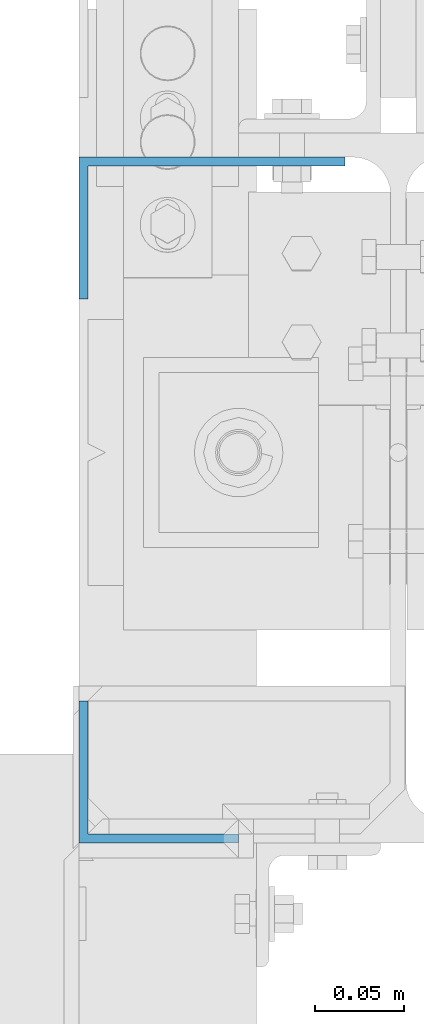
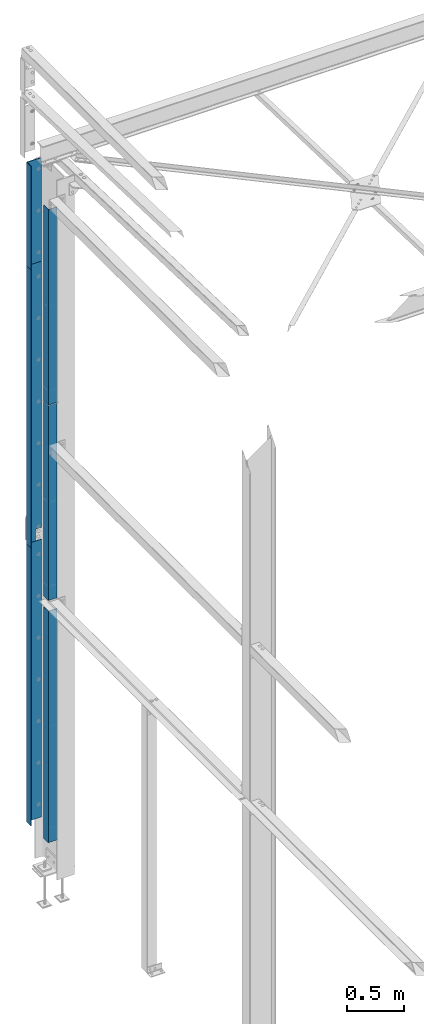
# One storey, part 345 of 496: 6 beams, 4 elements without a shape of their own.
"""IFC2X3 building model written with IfcOpenShell, lengths in millimetres."""

import ifcopenshell
import ifcopenshell.guid

model = None  # the IFC model being written
_history = None  # IfcOwnerHistory: only IFC2X3 demands one
_inside = {}  # id of a spatial element -> (the spatial element, [elements in it])
_under = {}  # id of a project, library or spatial element -> (it, [spatial elements below it])
_declared = {}  # id of a project -> (the project, [libraries it declares])
_typed = {}  # id of a type object -> (the type object, [elements of that type])
_made_of = {}  # id of a material, layer set ... -> (it, [elements and type objects made of it])


def new_model(schema):
    """Start an empty IFC model of exactly this schema.

    Asked for "IFC4X3", IfcOpenShell would pick the latest addendum, in which some entities
    have other attributes; the version numbers below select the first issue.
    IFC2X3 requires an IfcOwnerHistory on every rooted entity: one is made here for all.
    """
    global model, _history
    if schema == "IFC4X3":
        model = ifcopenshell.file(schema_version=(4, 3, 0, 0))
    else:
        model = ifcopenshell.file(schema=schema)
    _inside.clear()
    _under.clear()
    _declared.clear()
    _typed.clear()
    _made_of.clear()
    _history = None
    if model.schema == "IFC2X3":
        org = make("IfcOrganization", Name="unknown")
        user = make(
            "IfcPersonAndOrganization",
            ThePerson=make("IfcPerson", FamilyName="unknown"),
            TheOrganization=org,
        )
        app = make(
            "IfcApplication",
            ApplicationDeveloper=org,
            Version="unknown",
            ApplicationFullName="unknown",
            ApplicationIdentifier="unknown",
        )
        _history = make(
            "IfcOwnerHistory",
            OwningUser=user,
            OwningApplication=app,
            ChangeAction="ADDED",
            CreationDate=0,
        )
    return model


def make(cls, **values):
    """One entity of the class cls with the attributes given. An attribute that is None is left unset."""
    return model.create_entity(
        cls, **{name: value for name, value in values.items() if value is not None}
    )


def rooted(cls, **values):
    """An entity with a GlobalId (a new one), such as an element, a storey or a relation."""
    return make(cls, GlobalId=ifcopenshell.guid.new(), OwnerHistory=_history, **values)


def si_unit(unit_type, name, prefix=None):
    """IfcSIUnit, for example si_unit("LENGTHUNIT", "METRE", prefix="MILLI")."""
    return make("IfcSIUnit", UnitType=unit_type, Prefix=prefix, Name=name)


def assignment(units):
    """IfcUnitAssignment: the units of a project."""
    return None if units is None else make("IfcUnitAssignment", Units=units)


def point(xyz):
    """IfcCartesianPoint."""
    return None if xyz is None else make("IfcCartesianPoint", Coordinates=xyz)


def direction(xyz):
    """IfcDirection."""
    return None if xyz is None else make("IfcDirection", DirectionRatios=xyz)


def frame(location, z_axis=None, x_axis=None):
    """IfcAxis2Placement3D, a coordinate frame: its origin and axes. An axis left out is left unset."""
    return make(
        "IfcAxis2Placement3D",
        Location=point(location),
        Axis=direction(z_axis),
        RefDirection=direction(x_axis),
    )


def origin_with_axes():
    """The frame at (0, 0, 0) with the z axis (0, 0, 1) and the x axis (1, 0, 0) written out."""
    return frame((0.0, 0.0, 0.0), z_axis=(0.0, 0.0, 1.0), x_axis=(1.0, 0.0, 0.0))


def place(relative_to, where):
    """IfcLocalPlacement: puts the frame where relative to a parent placement (None: the world)."""
    return make(
        "IfcLocalPlacement", PlacementRelTo=relative_to, RelativePlacement=where
    )


def context(
    kind, dimensions, precision=None, world=None, true_north=None, identifier=None
):
    """IfcGeometricRepresentationContext, for example the 3D "Model" context."""
    return make(
        "IfcGeometricRepresentationContext",
        ContextIdentifier=identifier,
        ContextType=kind,
        CoordinateSpaceDimension=dimensions,
        Precision=precision,
        WorldCoordinateSystem=world,
        TrueNorth=true_north,
    )


def subcontext(parent, identifier, kind, view, scale=None):
    """IfcGeometricRepresentationSubContext, for example "Body" below "Model"."""
    return make(
        "IfcGeometricRepresentationSubContext",
        ContextIdentifier=identifier,
        ContextType=kind,
        ParentContext=parent,
        TargetScale=scale,
        TargetView=view,
    )


def project(units=None, contexts=None):
    """IfcProject with its units and contexts."""
    return rooted(
        "IfcProject",
        Name="project",
        RepresentationContexts=contexts,
        UnitsInContext=assignment(units),
    )


def spatial(cls, under=None, at=None, **own):
    """A site, building, storey or space (cls), placed at a placement, below another one or the project."""
    s = rooted(cls, ObjectPlacement=at, **own)
    if under is not None:
        _under.setdefault(under.id(), (under, []))[1].append(s)
    return s


def faces_of(points, faces, orient=None, outer=None):
    """IfcFace entities. A face is a list of loops; a loop is a list of indices into points, from 0.

    orient and outer hold one flag for each loop. By default every Orientation is true, the
    first loop of a face is its IfcFaceOuterBound and the others are IfcFaceBound.
    """
    made = []
    for i, loops in enumerate(faces):
        bounds = []
        for j, loop in enumerate(loops):
            is_outer = j == 0 if outer is None else outer[i][j]
            bounds.append(
                make(
                    "IfcFaceOuterBound" if is_outer else "IfcFaceBound",
                    Bound=make("IfcPolyLoop", Polygon=[points[k] for k in loop]),
                    Orientation=True if orient is None else orient[i][j],
                )
            )
        made.append(make("IfcFace", Bounds=bounds))
    return made


def faceted_brep(points, faces, orient=None, outer=None, voids=None):
    """IfcFacetedBrep: a solid bounded by flat faces; with voids (closed shells), ...WithVoids."""
    shared = [point(p) for p in points]
    hull = make("IfcClosedShell", CfsFaces=faces_of(shared, faces, orient, outer))
    if voids is None:
        return make("IfcFacetedBrep", Outer=hull)
    return make(
        "IfcFacetedBrepWithVoids",
        Outer=hull,
        Voids=[
            make(cls, CfsFaces=faces_of(shared, fs, o, b)) for cls, fs, o, b in voids
        ],
    )


def shape(context_of_items, identifier, shape_type, items):
    """IfcShapeRepresentation: the items that make up one representation, for example the "Body"."""
    return make(
        "IfcShapeRepresentation",
        ContextOfItems=context_of_items,
        RepresentationIdentifier=identifier,
        RepresentationType=shape_type,
        Items=items,
    )


def material(Name=None, Category=None):
    """IfcMaterial."""
    return make("IfcMaterial", Name=Name, Category=Category)


def made_of(thing, what):
    """Note that an element or type object is made of a material, layer set ...; save() writes the relation."""
    if what is not None:
        _made_of.setdefault(what.id(), (what, []))[1].append(thing)
    return thing


def type_object(cls, material=None, **own):
    """A type object (cls), such as IfcWallType, which elements share."""
    return made_of(rooted(cls, **own), material)


def element(
    cls,
    number,
    at=None,
    inside=None,
    cuts=None,
    type_object=None,
    material=None,
    context=None,
    identifier="Body",
    shape_type=None,
    held_by="IfcProductDefinitionShape",
    body=None,
    shapes=None,
    **own,
):
    """One element of the class cls, such as IfcWall. Its Tag is "e" and its number.

    at: its placement. inside: the storey or other place that contains it. cuts: it is an
    opening in that element (IfcRelVoidsElement). A single representation is given by context,
    identifier, shape_type and body (its items); several are given by shapes. held_by: the class
    of the entity that holds the representations. save() writes the other relations.
    """
    e = rooted(cls, Tag="e%d" % number, ObjectPlacement=at, **own)
    if body is not None:
        shapes = [shape(context, identifier, shape_type, body)]
    if shapes is not None:
        e.Representation = make(held_by, Representations=shapes)
    if inside is not None:
        _inside.setdefault(inside.id(), (inside, []))[1].append(e)
    if cuts is not None:
        rooted(
            "IfcRelVoidsElement", RelatingBuildingElement=cuts, RelatedOpeningElement=e
        )
    if type_object is not None:
        _typed.setdefault(type_object.id(), (type_object, []))[1].append(e)
    return made_of(e, material)


def aggregate(whole, parts):
    """IfcRelAggregates: a whole, such as a stair, and the parts it consists of."""
    return rooted("IfcRelAggregates", RelatingObject=whole, RelatedObjects=parts)


def save(model, path):
    """Write the relations noted so far, then the file.

    IfcRelAggregates (storeys below a building ...), IfcRelContainedInSpatialStructure (elements
    in a storey), IfcRelDefinesByType, IfcRelAssociatesMaterial and IfcRelDeclares: one each for
    every whole, place, type object, material and project.
    """
    for whole, parts in _under.values():
        aggregate(whole, parts)
    for where, things in _inside.values():
        rooted(
            "IfcRelContainedInSpatialStructure",
            RelatedElements=things,
            RelatingStructure=where,
        )
    for kind, things in _typed.values():
        rooted("IfcRelDefinesByType", RelatedObjects=things, RelatingType=kind)
    for what, things in _made_of.values():
        rooted("IfcRelAssociatesMaterial", RelatedObjects=things, RelatingMaterial=what)
    for by, libraries in _declared.values():
        rooted("IfcRelDeclares", RelatingContext=by, RelatedDefinitions=libraries)
    model.write(path)


model = new_model("IFC2X3")

# Units and contexts
model_context = context("Model", 3, precision=1e-05, world=origin_with_axes())
body_context = subcontext(model_context, "Body", "Model", "MODEL_VIEW")
ifc_project = project(units=[si_unit("LENGTHUNIT", "METRE", prefix="MILLI"), si_unit("AREAUNIT", "SQUARE_METRE"), si_unit("VOLUMEUNIT", "CUBIC_METRE"), si_unit("MASSUNIT", "GRAM", prefix="KILO"), si_unit("TIMEUNIT", "SECOND"), si_unit("PLANEANGLEUNIT", "RADIAN"), si_unit("SOLIDANGLEUNIT", "STERADIAN"), si_unit("THERMODYNAMICTEMPERATUREUNIT", "DEGREE_CELSIUS"), si_unit("LUMINOUSINTENSITYUNIT", "LUMEN")], contexts=[model_context])

# Site, building, storey
site_placement = place(None, origin_with_axes())
site = spatial("IfcSite", under=ifc_project, at=site_placement, CompositionType="ELEMENT")
building_placement = place(site_placement, origin_with_axes())
building = spatial("IfcBuilding", under=site, at=building_placement, Name="Undefined", CompositionType="ELEMENT")
storey_placement = place(building_placement, origin_with_axes())
storey = spatial("IfcBuildingStorey", under=building, at=storey_placement, Name="Undefined", CompositionType="ELEMENT", Elevation=0.0)

# Assembly, beam
assembly_1_placement = place(storey_placement, origin_with_axes())
assembly_1 = element("IfcElementAssembly", 1, at=assembly_1_placement, inside=storey, AssemblyPlace="NOTDEFINED", PredefinedType="NOTDEFINED")
ifc_material = material(Name="Undefined/S235-E24")
beam_type_1 = type_object("IfcBeamType", PredefinedType="NOTDEFINED")
beam_1_placement = place(assembly_1_placement, frame((-29.9999993378407, 15274.0000080908, 4750.00001534077), z_axis=(0.0, 0.0, 1.0), x_axis=(-1.0, 0.0, 0.0)))
beam_1 = element("IfcBeam", 2, at=beam_1_placement, type_object=beam_type_1, material=ifc_material, context=body_context, shape_type="Brep", body=[
    faceted_brep([(59.9999999940106, -2.49999997694431, -1375.00001545827), (60.0000000340106, 2.50000002305569, -1375.00001546327), (59.9999997840104, 2.50000002305569, -1499.99999999999), (59.9999997440104, -2.49999997694249, -1499.99999999999), (-5.98940275153836e-09, -2.50000000000182, -1375.00001533827), (-6.6398442299942e-10, 2.49999999999818, -1375.00001534327), (150.000030683736, -2.49999994235804, 1500.00000000003), (150.000030685615, -2.49999994235804, -1499.99999999997), (150.000031244983, 77.4999991111927, -1499.99999999994), (150.000031244301, 77.4999991099558, 1500.00000000006), (145.000030720613, 2.5000000557211, -1499.99999999997), (145.000030718734, 2.5000000557211, 1500.00000000003), (145.000031244301, 77.4999991449549, 1500.00000000006), (145.000031244983, 77.4999991461918, -1499.99999999994), (1.04409991763532e-09, 2.5, 1500.0), (-1.04046193882823e-09, -2.5, 1500.0)], [[[0, 1, 2, 3]], [[4, 5, 1, 0]], [[6, 7, 8, 9]], [[10, 11, 12, 13]], [[9, 8, 13, 12]], [[11, 14, 15, 6, 9, 12]], [[3, 7, 6, 15, 4, 0]], [[10, 13, 8, 7, 3, 2]], [[14, 11, 10, 2, 1, 5]], [[15, 14, 5, 4]]]),
])
aggregate(assembly_1, [beam_1])

assembly_2_placement = place(storey_placement, origin_with_axes())
assembly_2 = element("IfcElementAssembly", 3, at=assembly_2_placement, inside=storey, AssemblyPlace="NOTDEFINED", PredefinedType="NOTDEFINED")
beam_2_placement = place(assembly_2_placement, frame((-29.9999993497383, 15274.0000047621, 1749.99999991354), z_axis=(0.0, 0.0, 1.0), x_axis=(-1.0, 0.0, 0.0)))
beam_2 = element("IfcBeam", 4, at=beam_2_placement, type_object=beam_type_1, material=ifc_material, context=body_context, shape_type="Brep", body=[
    faceted_brep([(-1.04046193882823e-09, -2.5, -1500.0), (-1.04046193882823e-09, -2.5, 1500.0), (1.04409991763532e-09, 2.5, 1500.0), (1.04409991763532e-09, 2.5, -1500.0), (145.000030718734, 2.5000000557211, 1500.00000000003), (145.000030720613, 2.5000000557211, -1499.99999999997), (150.000030685615, -2.49999994235804, -1499.99999999997), (150.000030683736, -2.49999994235804, 1500.00000000003), (145.000031244301, 77.4999991449549, 1500.00000000006), (145.000031244983, 77.4999991461918, -1499.99999999994), (150.000031244301, 77.4999991099558, 1500.00000000006), (150.000031244983, 77.4999991111927, -1499.99999999994)], [[[0, 1, 2, 3]], [[3, 2, 4, 5]], [[1, 0, 6, 7]], [[5, 4, 8, 9]], [[4, 2, 1, 7, 10, 8]], [[7, 6, 11, 10]], [[6, 0, 3, 5, 9, 11]], [[10, 11, 9, 8]]]),
])
aggregate(assembly_2, [beam_2])

assembly_3_placement = place(storey_placement, origin_with_axes())
assembly_3 = element("IfcElementAssembly", 5, at=assembly_3_placement, inside=storey, Name="POTEAU", AssemblyPlace="NOTDEFINED", PredefinedType="NOTDEFINED")
beam_type_2 = type_object("IfcBeamType", PredefinedType="NOTDEFINED")
beam_3_placement = place(assembly_3_placement, frame((-89.999996529968, 14892.500004551, 1505.00000064084), z_axis=(0.0, 0.0, 1.0), x_axis=(-1.0, 0.0, 0.0)))
beam_3 = element("IfcBeam", 6, at=beam_3_placement, type_object=beam_type_2, material=ifc_material, context=body_context, shape_type="Brep", body=[
    faceted_brep([(9.51388301473344e-10, -2.50000000000182, -1250.0), (9.51388301473344e-10, -2.50000000000182, 1250.0), (-9.51388301473344e-10, 2.49999999999818, 1250.0), (-9.51388301473344e-10, 2.49999999999818, -1250.0), (90.0000228874677, 2.50000003424793, 1250.0), (90.0000228874677, 2.50000003424793, -1250.0), (85.0000233293048, -2.49999996765473, -1250.0), (85.0000233293048, -2.49999996765473, 1250.0), (90.0000299568624, -77.500000625234, 1250.0), (90.0000299568624, -77.500000625234, -1250.0), (85.0000299568624, -77.5000010670701, 1250.0), (85.0000299568624, -77.5000010670701, -1250.0)], [[[0, 1, 2, 3]], [[3, 2, 4, 5]], [[1, 0, 6, 7]], [[5, 4, 8, 9]], [[4, 2, 1, 7, 10, 8]], [[7, 6, 11, 10]], [[6, 0, 3, 5, 9, 11]], [[10, 11, 9, 8]]]),
])

assembly_4_placement = place(storey_placement, origin_with_axes())
assembly_4 = element("IfcElementAssembly", 7, at=assembly_4_placement, inside=storey, AssemblyPlace="NOTDEFINED", PredefinedType="NOTDEFINED")
beam_type_3 = type_object("IfcBeamType", PredefinedType="NOTDEFINED")
beam_4_placement = place(assembly_4_placement, frame((-29.9999993439691, 15274.0000097557, 6810.00003076487), z_axis=(0.0, 0.0, 1.0), x_axis=(-1.0, 0.0, 0.0)))
beam_4 = element("IfcBeam", 8, at=beam_4_placement, type_object=beam_type_3, material=ifc_material, context=body_context, shape_type="Brep", body=[
    faceted_brep([(1.07986153352613e-09, -2.50000000000182, -560.0), (8.41602343371051e-10, -2.50000000000182, 560.0), (-1.07985798081245e-09, 2.49999999999818, 560.0), (-8.41598790657372e-10, 2.49999999999818, -560.0), (145.000030554246, 2.5000000557211, 560.000000000031), (145.000030554938, 2.5000000557211, -559.999999999969), (150.00003051994, -2.49999994235804, -559.999999999968), (150.000030519248, -2.49999994235804, 560.000000000032), (145.000031079433, 77.4999989830121, 560.000000000062), (145.000031079688, 77.4999989834578, -559.999999999938), (150.000031079433, 77.4999989480129, 560.000000000064), (150.000031079688, 77.4999989484586, -559.999999999936)], [[[0, 1, 2, 3]], [[3, 2, 4, 5]], [[1, 0, 6, 7]], [[5, 4, 8, 9]], [[4, 2, 1, 7, 10, 8]], [[7, 6, 11, 10]], [[6, 0, 3, 5, 9, 11]], [[10, 11, 9, 8]]]),
])
aggregate(assembly_4, [beam_4])

# Beam
beam_type_4 = type_object("IfcBeamType", PredefinedType="NOTDEFINED")
beam_5_placement = place(assembly_3_placement, frame((-89.9999965222305, 14892.5000019105, 6034.999999412), z_axis=(0.0, 0.0, 1.0), x_axis=(-1.0, 0.0, 0.0)))
beam_5 = element("IfcBeam", 9, at=beam_5_placement, type_object=beam_type_4, material=ifc_material, context=body_context, shape_type="Brep", body=[
    faceted_brep([(9.51445144892205e-10, -2.5, -1055.0), (9.5145935574692e-10, -2.5, 1055.0), (-9.51416723182774e-10, 2.49999999999818, 1055.0), (-9.51430934037489e-10, 2.49999999999818, -1055.0), (90.0000228898876, 2.50000003424975, 1055.0), (90.0000228898876, 2.50000003424975, -1055.0), (85.0000233317248, -2.49999996765109, -1055.0), (85.0000233317248, -2.49999996765109, 1055.0), (90.0000299592824, -77.5000006271675, 1055.0), (90.0000299592824, -77.5000006271694, -1055.0), (85.0000299592824, -77.5000010690037, 1055.0), (85.0000299592824, -77.5000010690055, -1055.0)], [[[0, 1, 2, 3]], [[3, 2, 4, 5]], [[1, 0, 6, 7]], [[5, 4, 8, 9]], [[4, 2, 1, 7, 10, 8]], [[7, 6, 11, 10]], [[6, 0, 3, 5, 9, 11]], [[10, 11, 9, 8]]]),
])

beam_6_placement = place(assembly_3_placement, frame((-89.9999965164803, 14892.500006959, 3924.99999940539), z_axis=(0.0, 0.0, 1.0), x_axis=(-1.0, 0.0, 0.0)))
beam_6 = element("IfcBeam", 10, at=beam_6_placement, type_object=beam_type_4, material=ifc_material, context=body_context, shape_type="Brep", body=[
    faceted_brep([(9.51445144892205e-10, -2.5, -1055.0), (9.5145935574692e-10, -2.5, 1055.0), (-9.51416723182774e-10, 2.49999999999818, 1055.0), (-9.51430934037489e-10, 2.49999999999818, -1055.0), (90.0000228898876, 2.50000003424975, 1055.0), (90.0000228898876, 2.50000003424975, -1055.0), (85.0000233317248, -2.49999996765109, -1055.0), (85.0000233317248, -2.49999996765109, 1055.0), (90.0000299592824, -77.5000006271675, 1055.0), (90.0000299592824, -77.5000006271694, -1055.0), (85.0000299592824, -77.5000010690037, 1055.0), (85.0000299592824, -77.5000010690055, -1055.0)], [[[0, 1, 2, 3]], [[3, 2, 4, 5]], [[1, 0, 6, 7]], [[5, 4, 8, 9]], [[4, 2, 1, 7, 10, 8]], [[7, 6, 11, 10]], [[6, 0, 3, 5, 9, 11]], [[10, 11, 9, 8]]]),
])

aggregate(assembly_3, [beam_3, beam_5, beam_6])

save(model, "model.ifc")
